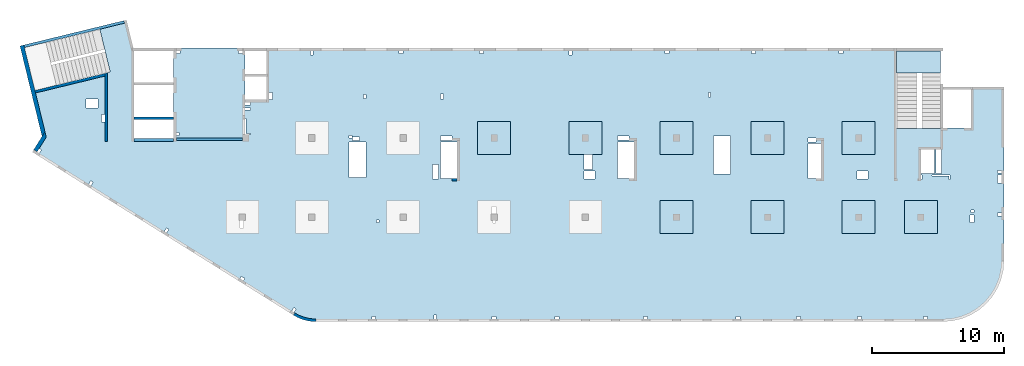
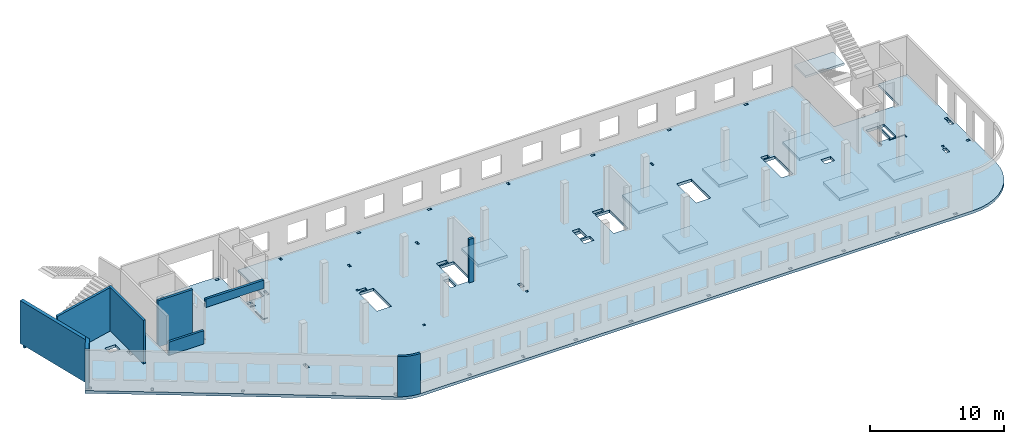
# One storey, part 2 of 7: 11 slabs, 10 walls.
"""IFC4 building model written with IfcOpenShell, lengths in millimetres."""

from ifc_helpers import new_model, entity, si_unit, converted_unit, derived_unit, direction, frame, origin, place, context, subcontext, project, spatial, indexed_curve, outline, extrude, material, type_object, element, save


model = new_model("IFC4")

# Units and contexts
model_context = context("Model", 3, precision=0.01, world=origin(), true_north=direction((6.12303176911189e-17, 1.0)))
plan_context = context("Plan", 3, precision=0.01, world=origin(), true_north=direction((6.12303176911189e-17, 1.0)))
body_context = subcontext(model_context, "Body", "Model", "MODEL_VIEW")
ifc_project = project(units=[si_unit("LENGTHUNIT", "METRE", prefix="MILLI"), si_unit("AREAUNIT", "SQUARE_METRE"), si_unit("VOLUMEUNIT", "CUBIC_METRE"), converted_unit("PLANEANGLEUNIT", "DEGREE", entity("IfcRatioMeasure", 0.0174532925199433), si_unit("PLANEANGLEUNIT", "RADIAN"), dimensions=[0, 0, 0, 0, 0, 0, 0]), si_unit("MASSUNIT", "GRAM", prefix="KILO"), derived_unit("MASSDENSITYUNIT", [(si_unit("MASSUNIT", "GRAM", prefix="KILO"), 1), (si_unit("LENGTHUNIT", "METRE"), -3)]), derived_unit("MOMENTOFINERTIAUNIT", [(si_unit("LENGTHUNIT", "METRE"), 4)]), si_unit("TIMEUNIT", "SECOND"), si_unit("FREQUENCYUNIT", "HERTZ"), si_unit("THERMODYNAMICTEMPERATUREUNIT", "DEGREE_CELSIUS"), derived_unit("THERMALTRANSMITTANCEUNIT", [(si_unit("MASSUNIT", "GRAM", prefix="KILO"), 1), (si_unit("THERMODYNAMICTEMPERATUREUNIT", "KELVIN"), -1), (si_unit("TIMEUNIT", "SECOND"), -3)]), derived_unit("VOLUMETRICFLOWRATEUNIT", [(si_unit("LENGTHUNIT", "METRE"), 3), (si_unit("TIMEUNIT", "SECOND"), -1)]), derived_unit("MASSFLOWRATEUNIT", [(si_unit("MASSUNIT", "GRAM", prefix="KILO"), 1), (si_unit("TIMEUNIT", "SECOND"), -1)]), derived_unit("ROTATIONALFREQUENCYUNIT", [(si_unit("TIMEUNIT", "SECOND"), -1)]), si_unit("ELECTRICCURRENTUNIT", "AMPERE"), si_unit("ELECTRICVOLTAGEUNIT", "VOLT"), si_unit("POWERUNIT", "WATT"), si_unit("FORCEUNIT", "NEWTON", prefix="KILO"), si_unit("ILLUMINANCEUNIT", "LUX"), si_unit("LUMINOUSFLUXUNIT", "LUMEN"), si_unit("LUMINOUSINTENSITYUNIT", "CANDELA"), derived_unit("USERDEFINED", [(si_unit("MASSUNIT", "GRAM", prefix="KILO"), -1), (si_unit("LENGTHUNIT", "METRE"), -2), (si_unit("TIMEUNIT", "SECOND"), 3), (si_unit("LUMINOUSFLUXUNIT", "LUMEN"), 1)]), derived_unit("LINEARVELOCITYUNIT", [(si_unit("LENGTHUNIT", "METRE"), 1), (si_unit("TIMEUNIT", "SECOND"), -1)]), si_unit("PRESSUREUNIT", "PASCAL"), derived_unit("USERDEFINED", [(si_unit("LENGTHUNIT", "METRE"), -2), (si_unit("MASSUNIT", "GRAM", prefix="KILO"), 1), (si_unit("TIMEUNIT", "SECOND"), -2)]), derived_unit("LINEARFORCEUNIT", [(si_unit("MASSUNIT", "GRAM", prefix="KILO"), 1), (si_unit("LENGTHUNIT", "METRE"), 1), (si_unit("TIMEUNIT", "SECOND"), -2), (si_unit("LENGTHUNIT", "METRE"), -1)]), derived_unit("PLANARFORCEUNIT", [(si_unit("MASSUNIT", "GRAM", prefix="KILO"), 1), (si_unit("LENGTHUNIT", "METRE"), 1), (si_unit("TIMEUNIT", "SECOND"), -2), (si_unit("LENGTHUNIT", "METRE"), -2)])], contexts=[model_context, plan_context])

# Site, building, storey
site_placement = place(None, origin())
site = spatial("IfcSite", under=ifc_project, at=site_placement, CompositionType="ELEMENT")
building_placement = place(site_placement, origin())
building = spatial("IfcBuilding", under=site, at=building_placement, CompositionType="ELEMENT")
storey_placement = place(building_placement, frame((0.0, 0.0, 12000.0)))
storey = spatial("IfcBuildingStorey", under=building, at=storey_placement, CompositionType="ELEMENT", Elevation=12000.0)

# Slabs
ifc_material = material()
slab_type_1 = type_object("IfcSlabType", PredefinedType="FLOOR", material=ifc_material)
slab_1_placement = place(storey_placement, origin())
element("IfcSlab", 1, at=slab_1_placement, inside=storey, type_object=slab_type_1, material=ifc_material, PredefinedType="FLOOR", context=body_context, shape_type="SweptSolid", body=[
    extrude(outline(indexed_curve([(-11615.3456191022, -15866.2384672249), (-11461.2227621515, -15956.6617307079), (-11302.2940263976, -16038.3432987954), (-11139.0547290428, -16111.0286027615), (-10972.0136215827, -16174.4911116315), (-10801.6913042325, -16228.5330381886), (-10628.6186034238, -16272.985955397), (-10453.3349174317, -16307.7113213217), (-10276.3865352866, -16332.6009109081), (-10098.3249342096, -16347.5771532763), (-9919.70506087959, -16352.5933734784), (37585.2949391216, -16352.5933734786), (38304.8933503634, -16295.9597502856), (39006.7728605103, -16127.4533884657), (39673.6508666178, -15851.2234738877), (40289.1066189344, -15474.0717038028), (40837.9855542575, -15005.2848064856), (41306.7724515748, -14456.4058711625), (41683.9242216596, -13840.9501188459), (41960.1541362377, -13174.0721127383), (42128.6604980575, -12472.1926025915), (42185.2941212505, -11752.5941913496), (42185.2941212505, 1417.40662652148), (39685.2941212505, 1417.40662652149), (39685.2941212505, -1682.59337347851), (37385.2949391216, -1682.59337347851), (37385.2949391216, -1722.59337347848), (34045.2949391217, -1722.59337347847), (34045.2949391217, 4347.4072658887), (-13659.7050608784, 4347.40726588886), (-13659.7050608784, 447.406626521855), (-15284.7050608784, 447.406626521859), (-15284.7050608784, 4347.40726588869), (-20684.7050608784, 4347.40726588871), (-20684.7050608784, -2502.5933734781), (-23684.7050608784, -2502.59337347809), (-23684.7050608784, 4347.40726588869), (-23734.0606732206, 4347.40726588869), (-24254.10794231, 6480.84192351009), (-24448.4183539383, 6433.47670491202), (-24401.0531353402, 6239.16629328373), (-26276.1486075532, 5782.09193381237), (-25485.1529405355, 2537.12235056864), (-31479.6214345329, 1075.90723492907), (-30648.3195083992, -2334.4141830962), (-31384.8454167592, -3513.12502953493), (-11615.3456191022, -15866.2384672249)], self_intersect=False), holes=[indexed_curve([(-26424.7050608784, -192.593373478052), (-27324.7050608784, -192.593373478052), (-27324.7050608784, 507.406626521949), (-26424.7050608784, 507.406626521947), (-26424.7050608784, -192.593373478052)], self_intersect=False), indexed_curve([(-25884.7050608784, -667.593373478048), (-25884.7050608784, -1227.59337347805), (-26134.7050608784, -1227.59337347805), (-26134.7050608784, -667.593373478048), (-25884.7050608784, -667.593373478048)], self_intersect=False), indexed_curve([(-30865.4736804199, -3248.07220556975), (-30695.8631316644, -3354.05457085215), (-30854.836679588, -3608.47039398543), (-31024.4472283436, -3502.48802870303), (-30865.4736804199, -3248.07220556975)], self_intersect=False), indexed_curve([(-26955.9505316053, -5690.96572532919), (-26786.3399828498, -5796.94809061159), (-26945.3135307734, -6051.36391374487), (-27114.9240795289, -5945.38154846246), (-26955.9505316053, -5690.96572532919)], self_intersect=False), indexed_curve([(-21223.1139836689, -9273.16967187448), (-21053.5034349134, -9379.15203715688), (-21212.476982837, -9633.56786029016), (-21382.0875315925, -9527.58549500775), (-21223.1139836689, -9273.16967187448)], self_intersect=False), indexed_curve([(-15551.7491458115, -12934.8797745334), (-15297.3333226782, -13093.853322457), (-15403.3156879606, -13263.4638712125), (-15657.7315110939, -13104.4903232889), (-15551.7491458115, -12934.8797745334)], self_intersect=False), indexed_curve([(-11580.7542869179, -15298.2671381792), (-11411.1437381624, -15404.2495034616), (-11570.117286086, -15658.6653265949), (-11739.7278348415, -15552.6829613125), (-11580.7542869179, -15298.2671381792)], self_intersect=False), indexed_curve([(-5384.7050608784, -16152.5933734782), (-5684.7050608784, -16152.5933734782), (-5684.7050608784, -15952.5933734782), (-5384.7050608784, -15952.5933734782), (-5384.7050608784, -16152.5933734782)], self_intersect=False), indexed_curve([(-789.705060878393, -16152.5933734782), (-989.705060878395, -16152.5933734782), (-989.705060878386, -15852.5933734782), (-789.705060878388, -15852.5933734782), (-789.705060878393, -16152.5933734782)], self_intersect=False), indexed_curve([(3735.29493912161, -16152.5933734782), (3435.29493912161, -16152.5933734782), (3435.29493912161, -15952.5933734782), (3735.29493912161, -15952.5933734782), (3735.29493912161, -16152.5933734782)], self_intersect=False), indexed_curve([(8485.29493912161, -16152.5933734783), (8185.29493912161, -16152.5933734782), (8185.29493912161, -15952.5933734782), (8485.29493912161, -15952.5933734783), (8485.29493912161, -16152.5933734783)], self_intersect=False), indexed_curve([(15185.2949391216, -16152.5933734783), (14885.2949391216, -16152.5933734782), (14885.2949391216, -15952.5933734783), (15185.2949391216, -15952.5933734783), (15185.2949391216, -16152.5933734783)], self_intersect=False), indexed_curve([(22185.2949391216, -16152.5933734783), (21885.2949391216, -16152.5933734783), (21885.2949391216, -15952.5933734783), (22185.2949391216, -15952.5933734783), (22185.2949391216, -16152.5933734783)], self_intersect=False), indexed_curve([(26785.2949391216, -16152.5933734783), (26485.2949391216, -16152.5933734783), (26485.2949391216, -15952.5933734783), (26785.2949391216, -15952.5933734783), (26785.2949391216, -16152.5933734783)], self_intersect=False), indexed_curve([(31385.2949391216, -16152.5933734783), (31085.2949391216, -16152.5933734783), (31085.2949391216, -15952.5933734783), (31385.2949391216, -15952.5933734783), (31385.2949391216, -16152.5933734783)], self_intersect=False), indexed_curve([(36385.2949391216, -16152.5933734783), (36085.2949391216, -16152.5933734783), (36085.2949391216, -15952.5933734783), (36385.2949391216, -15952.5933734783), (36385.2949391216, -16152.5933734783)], self_intersect=False), indexed_curve([(-20184.7050608784, 4147.4072658887), (-20184.7050608784, 3947.4072658887), (-20484.7050608784, 3947.40726588869), (-20484.7050608784, 4147.4072658887), (-20184.7050608784, 4147.4072658887)], self_intersect=False), indexed_curve([(-20284.7050608784, -2252.59337347809), (-20484.7050608784, -2252.59337347809), (-20484.7050608784, -2052.59337347809), (-20284.7050608784, -2052.59337347809), (-20284.7050608784, -2252.59337347809)], self_intersect=False), indexed_curve([(-15784.7050608784, 4147.4072658887), (-15484.7050608784, 4147.4072658887), (-15484.7050608784, 3947.4072658887), (-15784.7050608784, 3947.4072658887), (-15784.7050608784, 4147.4072658887)], self_intersect=False), indexed_curve([(-14854.7050608784, 247.406626521861), (-14854.7050608784, 47.4066265218589), (-15284.7050608784, 47.4066265218589), (-15284.7050608784, 247.406626521859), (-14854.7050608784, 247.406626521861)], self_intersect=False), indexed_curve([(-14854.7050608784, -177.593373478142), (-14854.7050608784, -337.59337347814), (-15284.7050608784, -337.59337347814), (-15284.7050608784, -177.593373478142), (-14854.7050608784, -177.593373478142)], self_intersect=False), indexed_curve([(-15284.7050608784, -2182.59337347814), (-15284.7050608784, -992.593373478139), (-15204.7050608784, -992.593373478139), (-15204.7050608784, -2102.59337347814), (-14864.7050608784, -2102.59337347814), (-14864.7050608784, -2182.59337347814), (-15284.7050608784, -2182.59337347814)], self_intersect=False), indexed_curve([(-13209.7050608784, 447.406626521855), (-13459.7050608784, 447.406626521855), (-13459.7050608784, 1007.40662652186), (-13209.7050608784, 1007.40662652186), (-13209.7050608784, 447.406626521855)], self_intersect=False), indexed_curve([(-10314.7050608784, 4147.4072658887), (-10214.7050608784, 4147.4072658887), (-10114.7050608784, 4147.40662652183), (-10114.7050608784, 3847.40726588869), (-10314.7050608784, 3847.40726588869), (-10314.7050608784, 4147.4072658887)], self_intersect=False), indexed_curve([(-3614.70506087836, 4147.40662652179), (-3314.70506087836, 4147.40662652179), (-3314.70506087836, 3947.40662652179), (-3614.70506087836, 3947.40662652179), (-3614.70506087836, 4147.40662652179)], self_intersect=False), indexed_curve([(2460.29493912165, 4147.40662652177), (2760.29493912165, 4147.40662652177), (2760.29493912164, 3947.40662652177), (2460.29493912164, 3947.40662652176), (2460.29493912165, 4147.40662652177)], self_intersect=False), indexed_curve([(16510.2949391216, 4147.40662652173), (16810.2949391216, 4147.40662652172), (16810.2949391216, 3947.40662652171), (16510.2949391216, 3947.40662652172), (16510.2949391216, 4147.40662652173)], self_intersect=False), indexed_curve([(9260.29493912165, 4147.4066265217), (9460.29493912165, 4147.4066265217), (9460.29493912166, 3847.4066265217), (9260.29493912165, 3847.4066265217), (9260.29493912165, 4147.4066265217)], self_intersect=False), indexed_curve([(23085.2949391216, 4147.40662652169), (23385.2949391216, 4147.40662652169), (23385.2949391216, 3947.4066265217), (23085.2949391216, 3947.4066265217), (23085.2949391216, 4147.40662652169)], self_intersect=False), indexed_curve([(29685.2949391216, 4147.40662652168), (29985.2949391216, 4147.40662652167), (29985.2949391216, 3947.40662652167), (29685.2949391216, 3947.40662652167), (29685.2949391216, 4147.40662652168)], self_intersect=False), indexed_curve([(-6114.70506087836, 847.407265888692), (-6114.70506087836, 527.407265888689), (-6314.70506087837, 527.407265888691), (-6314.70506087837, 847.407265888695), (-6114.70506087836, 847.407265888692)], self_intersect=False), indexed_curve([(-264.705060878365, 867.407265888811), (-264.70506087836, 507.407265888813), (-464.705060878358, 507.407265888813), (-464.705060878358, 867.407265888811), (-264.705060878365, 867.407265888811)], self_intersect=False), indexed_curve([(19975.2949391216, 997.407265888704), (19975.2949391216, 647.407265888701), (19825.2949391216, 647.407265888701), (19825.2949391216, 997.407265888704), (19975.2949391216, 997.407265888704)], self_intersect=False), indexed_curve([(37055.2949391217, -5127.59337347849), (37055.2949391217, -3322.59337347848), (37385.2949391216, -3322.59337347849), (37445.2949391217, -3322.59337347849), (37445.2949391217, -5127.59337347849), (37055.2949391217, -5127.59337347849)], self_intersect=False), indexed_curve([(35975.2949391217, -5247.59337347849), (35975.2949391217, -5587.59337347849), (35895.2949391217, -5587.59337347849), (35895.2949391217, -5247.59337347849), (35975.2949391217, -5247.59337347849)], self_intersect=False), indexed_curve([(38095.2949391216, -5247.59337347848), (38095.2949391216, -5587.59337347848), (38015.2949391216, -5587.59337347849), (38015.2949391216, -5327.59337347848), (36715.2949391216, -5327.59337347848), (36715.2949391216, -5247.59337347849), (38095.2949391216, -5247.59337347848)], self_intersect=False), indexed_curve([(41685.2941212505, -8342.59337347853), (41685.2941212505, -8142.59337347853), (41985.2941212505, -8142.59337347853), (41985.2941212505, -8342.59337347853), (41685.2941212505, -8342.59337347853)], self_intersect=False), indexed_curve([(41685.2941212505, -5102.59337347853), (41685.2941212505, -4902.59337347852), (41985.2941212505, -4902.59337347853), (41985.2941212505, -5102.59337347853), (41685.2941212505, -5102.59337347853)], self_intersect=False), indexed_curve([(41685.2941212505, -5867.59337347854), (41685.2941212505, -5267.59337347853), (41985.2941212505, -5267.59337347854), (41985.2941212505, -5867.59337347854), (41685.2941212505, -5867.59337347854)], self_intersect=False), indexed_curve([(39895.2941212505, -8272.5933734785), (39895.2941212505, -8852.59337347852), (39595.2941212505, -8852.59337347852), (39595.2941212505, -8272.59337347851), (39895.2941212505, -8272.5933734785)], self_intersect=False), indexed_curve([(39905.2941212505, -7892.59337347851), (39905.2941212505, -8092.59337347851), (39705.2941212505, -8092.59337347851), (39705.2941212505, -7892.5933734785), (39905.2941212505, -7892.59337347851)], self_intersect=False), indexed_curve([(31900.2949391216, -4967.59337347845), (31900.2949391216, -5567.59337347845), (31070.2949391216, -5567.59337347845), (31070.2949391216, -4967.59337347845), (31900.2949391216, -4967.59337347845)], self_intersect=False), indexed_curve([(27345.2949391216, -5527.59337347843), (27345.2949391216, -2857.59337347842), (28345.2949391217, -2857.59337347842), (28345.2949391217, -5527.59337347844), (27345.2949391216, -5527.59337347843)], self_intersect=False), indexed_curve([(27345.2949391216, -2452.59337347842), (27945.2949391216, -2452.59337347842), (27945.2949391216, -2737.59337347842), (27345.2949391216, -2737.59337347842), (27345.2949391216, -2452.59337347842)], self_intersect=False), indexed_curve([(21465.2949391216, -2317.59337347838), (21465.2949391216, -5177.59337347839), (20205.2949391216, -5177.59337347839), (20205.2949391216, -2317.59337347838), (21465.2949391216, -2317.59337347838)], self_intersect=False), indexed_curve([(12925.2949391216, -5527.59322391854), (12925.2949391216, -2752.59322391854), (14185.2949391216, -2752.59322391854), (14185.2949391216, -5527.59322391853), (12925.2949391216, -5527.59322391854)], self_intersect=False), indexed_curve([(12925.2949391216, -2602.59337347834), (12925.2949391216, -2312.59337347833), (13785.2949391216, -2312.59337347833), (13785.2949391216, -2602.59337347834), (12925.2949391216, -2602.59337347834)], self_intersect=False), indexed_curve([(10395.2949391217, -3702.59337347839), (10485.2949391216, -3702.59337347838), (11015.2949391216, -3702.59337347839), (11015.2949391216, -4822.59337347839), (10395.2949391217, -4822.59337347839), (10395.2949391217, -3702.59337347839)], self_intersect=False), indexed_curve([(10370.2949391216, -4967.59337347839), (11200.2949391216, -4967.59337347839), (11200.2949391216, -5567.59337347838), (10370.2949391216, -5567.59337347839), (10370.2949391216, -4967.59337347839)], self_intersect=False), indexed_curve([(3485.29493912162, -8702.59337347826), (3585.29493912162, -8702.59337347826), (3685.29493912163, -8702.59337347826), (3685.29493912163, -8902.59337347827), (3485.29493912163, -8902.59337347827), (3485.29493912162, -8702.59337347826)], self_intersect=False), indexed_curve([(3405.29493912162, -8162.59337347827), (3405.29493912162, -7652.59337347826), (3735.29493912162, -7652.59337347827), (3735.29493912162, -8162.59337347826), (3405.29493912162, -8162.59337347827)], self_intersect=False), indexed_curve([(-474.705060878365, -5527.5932239185), (-474.705060878365, -2752.5932239185), (785.29493912163, -2752.5932239185), (785.294939121635, -5527.59322391849), (-474.705060878365, -5527.5932239185)], self_intersect=False), indexed_curve([(-474.705060878365, -2312.59337347824), (385.29493912163, -2312.59337347824), (385.294939121626, -2632.59337347824), (-474.705060878369, -2632.59337347824), (-474.705060878365, -2312.59337347824)], self_intersect=False), indexed_curve([(-1094.70506087836, -5567.5932239185), (-1094.70506087837, -4477.5932239185), (-634.705060878363, -4477.5932239185), (-634.705060878363, -5567.5932239185), (-1094.70506087836, -5567.5932239185)], self_intersect=False), indexed_curve([(-5134.70506087838, -8662.5933734782), (-5134.70506087839, -8862.5933734782), (-5334.70506087839, -8862.5933734782), (-5334.70506087839, -8662.5933734782), (-5134.70506087838, -8662.5933734782)], self_intersect=False), indexed_curve([(-15644.7050608784, -8702.59337347814), (-15484.7050608784, -8702.59337347813), (-15394.7050608784, -8702.59337347813), (-15394.7050608784, -9262.59337347813), (-15644.7050608784, -9262.59337347814), (-15644.7050608784, -8702.59337347814)], self_intersect=False), indexed_curve([(-6134.70506087837, -2752.59337347818), (-6134.70506087837, -5462.59337347818), (-7394.70506087837, -5462.59337347818), (-7394.70506087837, -2752.59337347818), (-6134.70506087837, -2752.59337347818)], self_intersect=False), indexed_curve([(-7194.70506087837, -2462.59337347819), (-7394.70506087837, -2462.59337347819), (-7394.70506087837, -2272.59337347818), (-7194.70506087837, -2272.59337347818), (-7194.70506087837, -2462.59337347819)], self_intersect=False), indexed_curve([(-6594.70506087837, -2632.59337347819), (-7154.70506087837, -2632.59337347819), (-7154.70506087837, -2382.5933734782), (-6594.70506087837, -2382.5933734782), (-6594.70506087837, -2632.59337347819)], self_intersect=False), indexed_curve([(36935.2949391217, -3322.59337347849), (36935.2949391217, -5127.59337347849), (35895.2949391217, -5127.59337347849), (35895.2949391217, -3322.59337347849), (36935.2949391217, -3322.59337347849)], self_intersect=False)]), frame((31384.7053294331, 16152.592599834, -400.0)), (0.0, 0.0, 1.0), 249.999999999999),
])
slab_type_2 = type_object("IfcSlabType", PredefinedType="FLOOR", material=ifc_material)
slab_2_placement = place(storey_placement, origin())
element("IfcSlab", 2, at=slab_2_placement, inside=storey, type_object=slab_type_2, material=ifc_material, PredefinedType="FLOOR", context=body_context, shape_type="SweptSolid", body=[
    extrude(outline(indexed_curve([(-1250.0, -1250.0), (1250.0, -1250.0), (1250.0, 1250.0), (-1250.0, 1250.0), (-1250.0, -1250.0)], self_intersect=False)), frame((48770.0002685547, 7699.99922635573, -400.0), z_axis=(0.0, 0.0, -1.0), x_axis=(0.0, 1.0, 0.0)), (0.0, 0.0, 1.0), 249.999999999999),
])
slab_type_3 = type_object("IfcSlabType", PredefinedType="FLOOR", material=ifc_material)
slab_3_placement = place(storey_placement, origin())
element("IfcSlab", 3, at=slab_3_placement, inside=storey, type_object=slab_type_3, material=ifc_material, PredefinedType="FLOOR", context=body_context, shape_type="SweptSolid", body=[
    extrude(outline(indexed_curve([(-1250.0, -1249.99999999999), (1250.0, -1249.99999999999), (1250.0, 1250.00000000001), (-1250.0, 1250.00000000001), (-1250.0, -1249.99999999999)], self_intersect=False)), frame((55670.0002685547, 7699.99922635571, -400.0), z_axis=(0.0, 0.0, -1.0), x_axis=(0.0, 1.0, 0.0)), (0.0, 0.0, 1.0), 249.999999999999),
])
slab_type_4 = type_object("IfcSlabType", PredefinedType="FLOOR", material=ifc_material)
slab_4_placement = place(storey_placement, origin())
element("IfcSlab", 4, at=slab_4_placement, inside=storey, type_object=slab_type_4, material=ifc_material, PredefinedType="FLOOR", context=body_context, shape_type="SweptSolid", body=[
    extrude(outline(indexed_curve([(-1250.0, -1250.0), (1250.0, -1250.0), (1250.0, 1250.0), (-1250.0, 1250.0), (-1250.0, -1250.0)], self_intersect=False)), frame((62570.0002685547, 7699.99922635568, -400.0), z_axis=(0.0, 0.0, -1.0), x_axis=(0.0, 1.0, 0.0)), (0.0, 0.0, 1.0), 249.999999999999),
])
slab_type_5 = type_object("IfcSlabType", PredefinedType="FLOOR", material=ifc_material)
slab_5_placement = place(storey_placement, origin())
element("IfcSlab", 5, at=slab_5_placement, inside=storey, type_object=slab_type_5, material=ifc_material, PredefinedType="FLOOR", context=body_context, shape_type="SweptSolid", body=[
    extrude(outline(indexed_curve([(-1250.0, -1249.99999999999), (1250.0, -1249.99999999999), (1250.0, 1250.00000000001), (-1250.0, 1250.00000000001), (-1250.0, -1249.99999999999)], self_intersect=False)), frame((67270.0002685547, 7699.99922635567, -400.0), z_axis=(0.0, 0.0, -1.0), x_axis=(0.0, 1.0, 0.0)), (0.0, 0.0, 1.0), 249.999999999999),
])
slab_type_6 = type_object("IfcSlabType", PredefinedType="FLOOR", material=ifc_material)
slab_6_placement = place(storey_placement, origin())
element("IfcSlab", 6, at=slab_6_placement, inside=storey, type_object=slab_type_6, material=ifc_material, PredefinedType="FLOOR", context=body_context, shape_type="SweptSolid", body=[
    extrude(outline(indexed_curve([(-1250.0, -1250.0), (1250.0, -1250.0), (1250.0, 1250.0), (-1250.0, 1250.0), (-1250.0, -1250.0)], self_intersect=False)), frame((62570.0002685547, 13699.9992263555, -400.0), z_axis=(0.0, 0.0, -1.0), x_axis=(0.0, 1.0, 0.0)), (0.0, 0.0, 1.0), 249.999999999999),
])
slab_type_7 = type_object("IfcSlabType", PredefinedType="FLOOR", material=ifc_material)
slab_7_placement = place(storey_placement, origin())
element("IfcSlab", 7, at=slab_7_placement, inside=storey, type_object=slab_type_7, material=ifc_material, PredefinedType="FLOOR", context=body_context, shape_type="SweptSolid", body=[
    extrude(outline(indexed_curve([(-1250.0, -1250.0), (1250.0, -1250.0), (1250.0, 1250.0), (-1250.0, 1250.0), (-1250.0, -1250.0)], self_intersect=False)), frame((55670.0002685547, 13699.9992263555, -400.0), z_axis=(0.0, 0.0, -1.0), x_axis=(0.0, 1.0, 0.0)), (0.0, 0.0, 1.0), 249.999999999999),
])
slab_type_8 = type_object("IfcSlabType", PredefinedType="FLOOR", material=ifc_material)
slab_8_placement = place(storey_placement, origin())
element("IfcSlab", 8, at=slab_8_placement, inside=storey, type_object=slab_type_8, material=ifc_material, PredefinedType="FLOOR", context=body_context, shape_type="SweptSolid", body=[
    extrude(outline(indexed_curve([(-1250.0, -1250.0), (1250.0, -1250.0), (1250.0, 1250.0), (-1250.0, 1250.0), (-1250.0, -1250.0)], self_intersect=False)), frame((48770.0002685547, 13699.9992263556, -400.0), z_axis=(0.0, 0.0, -1.0), x_axis=(0.0, 1.0, 0.0)), (0.0, 0.0, 1.0), 249.999999999999),
])
slab_type_9 = type_object("IfcSlabType", PredefinedType="FLOOR", material=ifc_material)
slab_9_placement = place(storey_placement, origin())
element("IfcSlab", 9, at=slab_9_placement, inside=storey, type_object=slab_type_9, material=ifc_material, PredefinedType="FLOOR", context=body_context, shape_type="SweptSolid", body=[
    extrude(outline(indexed_curve([(-1250.0, -1250.0), (1250.0, -1250.0), (1250.0, 1250.0), (-1250.0, 1250.0), (-1250.0, -1250.0)], self_intersect=False)), frame((41870.0002685547, 13699.9992263556, -400.0), z_axis=(0.0, 0.0, -1.0), x_axis=(0.0, 1.0, 0.0)), (0.0, 0.0, 1.0), 249.999999999999),
])
slab_type_10 = type_object("IfcSlabType", PredefinedType="FLOOR", material=ifc_material)
slab_10_placement = place(storey_placement, origin())
element("IfcSlab", 10, at=slab_10_placement, inside=storey, type_object=slab_type_10, material=ifc_material, PredefinedType="FLOOR", context=body_context, shape_type="SweptSolid", body=[
    extrude(outline(indexed_curve([(-1250.0, -1250.0), (1250.0, -1250.0), (1250.0, 1250.0), (-1250.0, 1250.0), (-1250.0, -1250.0)], self_intersect=False)), frame((34970.0002685547, 13699.9992263556, -400.0), z_axis=(0.0, 0.0, -1.0), x_axis=(0.0, 1.0, 0.0)), (0.0, 0.0, 1.0), 249.999999999999),
])
slab_type_11 = type_object("IfcSlabType", PredefinedType="FLOOR", material=ifc_material)
slab_11_placement = place(storey_placement, origin())
element("IfcSlab", 11, at=slab_11_placement, inside=storey, type_object=slab_type_11, material=ifc_material, PredefinedType="FLOOR", context=body_context, shape_type="SweptSolid", body=[
    extrude(outline(indexed_curve([(-834.999999999999, -1670.00000000001), (835.000000000001, -1670.00000000001), (835.000000000001, 1670.00000000002), (-834.999999999999, 1670.00000000002), (-834.999999999999, -1670.00000000001)], self_intersect=False)), frame((67100.0002685547, 19464.999226356, 1920.0), z_axis=(0.0, 0.0, -1.0), x_axis=(0.0, 1.0, 0.0)), (0.0, 0.0, 1.0), 200.0),
])

# Walls
wall_type_1 = type_object("IfcWallType", PredefinedType="STANDARD")
wall_1_placement = place(storey_placement, frame((19822.3508916672, 371.159404898124, -150.0)))
element("IfcWall", 12, at=wall_1_placement, inside=storey, type_object=wall_type_1, material=ifc_material, PredefinedType="NOTDEFINED", context=body_context, shape_type="SweptSolid", body=[
    extrude(outline(indexed_curve([(1647.48298908956, -371.159642137684), (1479.53495854193, -366.732336838998), (1312.09852486252, -352.905454552832), (1145.69934172072, -329.72240370142), (980.859806418502, -297.255965670987), (818.09741986465, -255.608066320247), (657.923161920899, -204.909455992096), (500.839887220395, -145.319299033065), (347.340746494629, -77.024674109233), (197.907638365059, -0.239986887291593), (53.0096964598414, 84.7937030753815), (-53.0096964598197, -84.7937030753918), (101.553010904459, -175.499182842681), (260.953382356765, -257.405447245706), (424.69099282044, -330.255357933605), (592.251800794088, -393.820208274097), (763.109762144871, -447.900441360165), (936.728481583211, -492.326276503471), (1112.5628966341, -526.958242247616), (1290.06098881835, -551.687614227945), (1468.66551667174, -566.436756503237), (1647.81576516126, -571.159365287708), (1647.48298908956, -371.159642137684)], self_intersect=False)), origin(), (0.0, 0.0, 1.0), 3650.0),
])
wall_2_placement = place(storey_placement, frame((5600.00026855469, 13449.9992263559, -150.0), z_axis=(0.0, 0.0, 1.0), x_axis=(0.0, 1.0, 0.0)))
element("IfcWall", 13, at=wall_2_placement, inside=storey, type_object=wall_type_1, material=ifc_material, PredefinedType="NOTDEFINED", context=body_context, shape_type="SweptSolid", body=[
    extrude(outline(indexed_curve([(5191.05764338749, -100.0), (5142.30552742916, 99.9999999999995), (4936.44934265344, 100.0), (-1.37676332088153e-13, 100.0), (1.37676332088153e-13, -100.0), (5191.05764338749, -100.0)], self_intersect=False)), origin(), (0.0, 0.0, 1.0), 3950.0),
])
wall_3_placement = place(storey_placement, frame((220.235605211587, 17202.3781658972, -150.0), z_axis=(0.0, 0.0, 1.0), x_axis=(0.971552058141473, 0.236826092990337, 0.0)))
element("IfcWall", 14, at=wall_3_placement, inside=storey, type_object=wall_type_1, material=ifc_material, PredefinedType="NOTDEFINED", context=body_context, shape_type="SweptSolid", body=[
    extrude(outline(indexed_curve([(5409.98499256816, -100.000000000001), (5458.73710852649, 100.000000000001), (2.16573425859679e-12, 99.9999999999995), (1.77657888400518e-12, -100.0), (5409.98499256816, -100.000000000001)], self_intersect=False)), origin(), (0.0, 0.0, 1.0), 3950.0),
])
wall_4_placement = place(storey_placement, frame((7700.00026855469, 15199.9998657227, -400.0)))
element("IfcWall", 15, at=wall_4_placement, inside=storey, type_object=wall_type_1, material=ifc_material, PredefinedType="NOTDEFINED", context=body_context, shape_type="SweptSolid", body=[
    extrude(outline(indexed_curve([(3000.0, 99.9999999999989), (-2.88764567812902e-13, 99.9999999999989), (2.88764567812902e-13, -99.9999999999989), (3000.0, -99.9999999999989), (3000.0, 99.9999999999989)], self_intersect=False)), origin(), (0.0, 0.0, 1.0), 4200.0),
])
wall_5_placement = place(storey_placement, frame((32170.0002685547, 10524.9993759155, -150.0), z_axis=(0.0, 0.0, 1.0), x_axis=(-1.0, 0.0, 0.0)))
element("IfcWall", 16, at=wall_5_placement, inside=storey, type_object=wall_type_1, material=ifc_material, PredefinedType="NOTDEFINED", context=body_context, shape_type="SweptSolid", body=[
    extrude(outline(indexed_curve([(399.999999999995, 99.9999999999982), (-3.60955709766131e-13, 99.9999999999989), (3.60955709766131e-13, -99.9999999999989), (399.999999999996, -99.9999999999996), (399.999999999995, 99.9999999999982)], self_intersect=False)), origin(), (0.0, 0.0, 1.0), 3950.0),
])
wall_6_placement = place(storey_placement, frame((10900.0002685547, 13599.9992263559, 3050.0)))
element("IfcWall", 17, at=wall_6_placement, inside=storey, type_object=wall_type_1, material=ifc_material, PredefinedType="NOTDEFINED", context=body_context, shape_type="SweptSolid", body=[
    extrude(outline(indexed_curve([(4999.99925537109, 99.9999999999989), (-3.03202841358267e-13, 99.9999999999989), (3.03202841358267e-13, -99.9999999999989), (4999.99925537109, -99.9999999999989), (4999.99925537109, 99.9999999999989)], self_intersect=False)), origin(), (0.0, 0.0, 1.0), 749.999999999998),
])
wall_7_placement = place(storey_placement, frame((-618.128763974178, 20641.672451718, -900.0), z_axis=(0.0, 0.0, 1.0), x_axis=(0.971552058141473, 0.236826092990337, 0.0)))
element("IfcWall", 18, at=wall_7_placement, inside=storey, type_object=wall_type_1, material=ifc_material, PredefinedType="NOTDEFINED", context=body_context, shape_type="SweptSolid", body=[
    extrude(outline(indexed_curve([(7799.99206966276, 100.000000000001), (6.34492458573277e-14, 100.0), (-6.34492458573277e-14, -100.0), (7799.99206966276, -99.9999999999989), (7799.99206966276, 100.000000000001)], self_intersect=False)), origin(), (0.0, 0.0, 1.0), 750.000000000003),
])
wall_8_placement = place(storey_placement, frame((7700.00026855469, 13549.9992263559, -150.0)))
element("IfcWall", 19, at=wall_8_placement, inside=storey, type_object=wall_type_1, material=ifc_material, PredefinedType="NOTDEFINED", context=body_context, shape_type="SweptSolid", body=[
    extrude(outline(indexed_curve([(3000.0, 99.9999999999989), (-2.88764567812902e-13, 99.9999999999989), (2.88764567812902e-13, -99.9999999999989), (3000.0, -99.9999999999989), (3000.0, 99.9999999999989)], self_intersect=False)), origin(), (0.0, 0.0, 1.0), 1200.0),
])
wall_type_2 = type_object("IfcWallType", PredefinedType="STANDARD")
wall_9_placement = place(storey_placement, frame((233.05018952286, 12729.5913450927, -150.0), z_axis=(0.0, 0.0, 1.0), x_axis=(0.529911826412024, 0.848052743777575, 0.0)))
element("IfcWall", 20, at=wall_9_placement, inside=storey, type_object=wall_type_2, material=ifc_material, PredefinedType="NOTDEFINED", context=body_context, shape_type="SweptSolid", body=[
    extrude(outline(indexed_curve([(1316.31557757947, -150.0), (1609.08571844498, 150.0), (2.10651496246328e-12, 150.0), (9.22129039793163e-13, -150.0), (1316.31557757947, -150.0)], self_intersect=False)), origin(), (0.0, 0.0, 1.0), 3650.0),
])
wall_10_placement = place(storey_placement, frame((-787.544181994463, 20703.3037435836, -400.0), z_axis=(0.0, 0.0, 1.0), x_axis=(0.236826092990339, -0.971552058141473, 0.0)))
element("IfcWall", 21, at=wall_10_placement, inside=storey, type_object=wall_type_2, material=ifc_material, PredefinedType="NOTDEFINED", context=body_context, shape_type="SweptSolid", body=[
    extrude(outline(indexed_curve([(7050.16407046696, -150.0), (6757.39392960146, 150.0), (-2.49567033705489e-13, 150.0), (1.86117787848161e-13, -150.0), (7050.16407046696, -150.0)], self_intersect=False)), origin(), (0.0, 0.0, 1.0), 3900.0),
])

save(model, "model.ifc")
